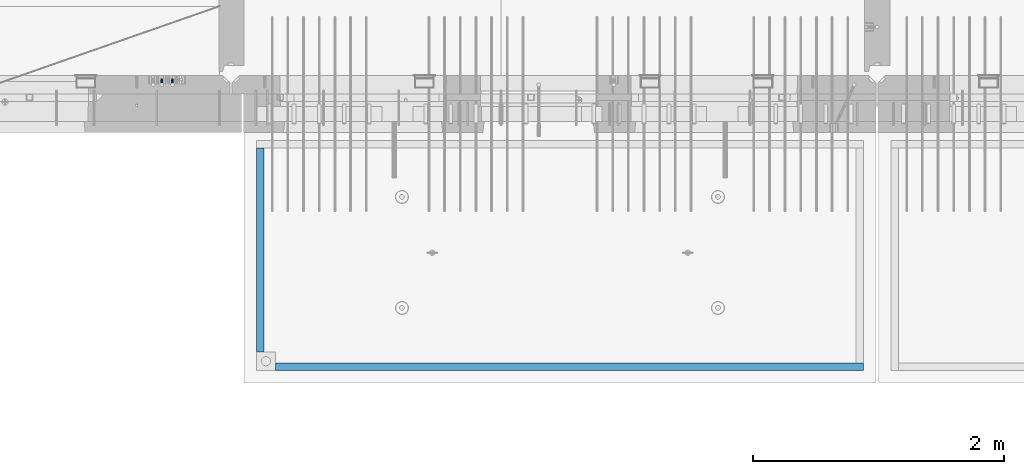
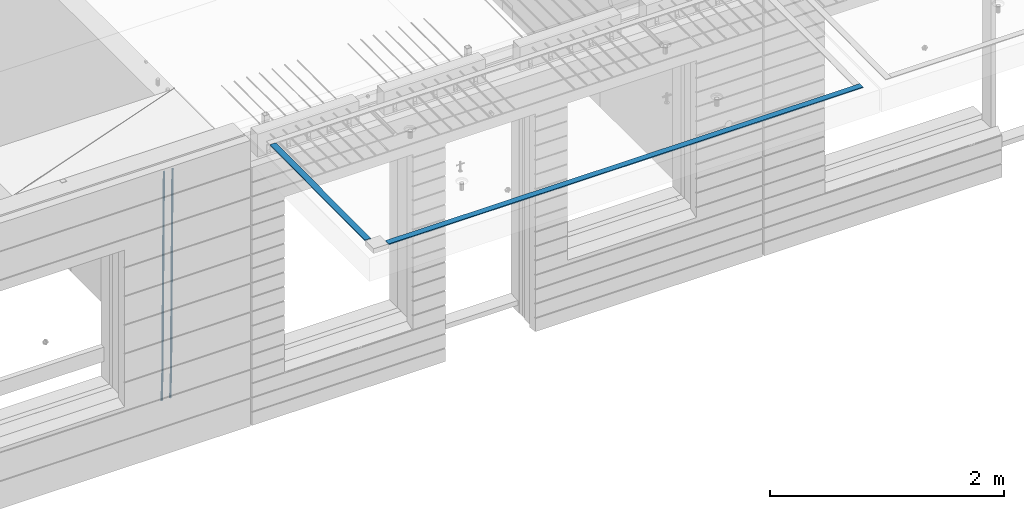
# One storey, part 95 of 349: 4 beams, 2 elements without a shape of their own.
"""IFC2X3 building model written with IfcOpenShell, lengths in millimetres."""

from ifc_helpers import new_model, si_unit, frame, origin_with_axes, place, context, subcontext, project, spatial, faceted_brep, material, type_object, element, aggregate, save


model = new_model("IFC2X3")

# Units and contexts
model_context = context("Model", 3, precision=1e-05, world=origin_with_axes())
body_context = subcontext(model_context, "Body", "Model", "MODEL_VIEW")
ifc_project = project(units=[si_unit("LENGTHUNIT", "METRE", prefix="MILLI"), si_unit("AREAUNIT", "SQUARE_METRE"), si_unit("VOLUMEUNIT", "CUBIC_METRE"), si_unit("MASSUNIT", "GRAM", prefix="KILO"), si_unit("TIMEUNIT", "SECOND"), si_unit("PLANEANGLEUNIT", "RADIAN"), si_unit("SOLIDANGLEUNIT", "STERADIAN"), si_unit("THERMODYNAMICTEMPERATUREUNIT", "DEGREE_CELSIUS"), si_unit("LUMINOUSINTENSITYUNIT", "LUMEN")], contexts=[model_context])

# Site, building, storey
site_placement = place(None, origin_with_axes())
site = spatial("IfcSite", under=ifc_project, at=site_placement, CompositionType="ELEMENT")
building_placement = place(site_placement, origin_with_axes())
building = spatial("IfcBuilding", under=site, at=building_placement, CompositionType="ELEMENT")
storey_placement = place(building_placement, origin_with_axes())
storey = spatial("IfcBuildingStorey", under=building, at=storey_placement, Name="4", CompositionType="ELEMENT", Elevation=0.0)

# Assembly, beams
assembly_1_placement = place(storey_placement, origin_with_axes())
assembly_1 = element("IfcElementAssembly", 1, at=assembly_1_placement, inside=storey, AssemblyPlace="NOTDEFINED", PredefinedType="REINFORCEMENT_UNIT")
ifc_material_1 = material()
beam_type_1 = type_object("IfcBeamType", Name="D20", PredefinedType="NOTDEFINED")
beam_1_placement = place(assembly_1_placement, frame((16189.9999999961, 7965.00000227913, 90990.0), z_axis=(0.00020576299992186, -0.999642804629538, -0.0267249099901004), x_axis=(-4.30000201928125e-08, -0.0267249099948059, 0.999642825806181)))
beam_1 = element("IfcBeam", 2, at=beam_1_placement, type_object=beam_type_1, material=ifc_material_1, Name="JM20", ObjectType="D20", context=body_context, shape_type="Brep", body=[
    faceted_brep([(0.0, -10.0, 0.0), (-4.19531716033816e-08, -7.07106781186667, -7.07106781187031), (60.4266690400545, -7.0710677960451, -7.07106780570757), (60.4266690441291, -9.99999998418934, 6.15546014159918e-09), (0.0, 0.0, -10.0), (60.426669036824, 1.58106558956206e-08, -9.99999999384454), (4.196772351861e-08, 7.07106781186303, -7.07106781186667), (60.4266690363438, 7.07106782768096, -7.07106780570757), (0.0, 10.0, 0.0), (60.4266690388904, 10.0000000158179, 6.15182216279209e-09), (4.196772351861e-08, 7.07106781185939, 7.07106781185939), (60.4266690429649, 7.07106782768096, 7.07106781802577), (0.0, 0.0, 10.0), (60.4266690461809, 1.58179318532348e-08, 10.0000000061555), (-4.19531716033816e-08, -7.07106781187031, 7.07106781185939), (60.4266690466611, -7.07106779605238, 7.07106781802213), (61.0378400410118, -7.07106779588503, -7.07106780564936), (60.991799419251, -9.99999998403655, 6.21366780251265e-09), (61.0569027789461, 1.5985278878361e-08, -9.99999999378269), (61.0378209396877, 7.07106782784831, -7.07106780564936), (60.9917724058905, 10.0000000159635, 6.21366780251265e-09), (60.9457317841297, 7.07106782781193, 7.0710678180767), (60.9266690461809, 1.59488990902901e-08, 10.0000000062028), (60.9457508854539, -7.07106779591413, 7.0710678180767), (61.6489592143771, -7.07106614513759, -7.06310863441468), (61.5568818710308, -9.9999984576425, 0.00735959856683621), (61.6870830769039, 1.71821739058942e-06, -9.99179257185824), (61.6489210170112, 7.07106947854481, -7.06310888312146), (61.556827851804, 10.0000015422847, 0.00735924683976918), (61.4647505084577, 7.07106922979438, 7.07782747982128), (61.4266266459163, 1.36643211590126e-06, 10.0065114172685), (61.464788705809, -7.07106639389531, 7.07782772852806), (176.543135720174, -7.07075579406956, -5.56673531796696), (176.451058376813, -9.99968810657447, 1.50373291501455), (176.581259582701, 0.000312069292704109, -8.49541925541052), (176.543097522794, 7.07137982961285, -5.56673556667374), (176.451004357587, 10.00031189336, 1.50373256329476), (176.35892701424, 7.07137958085514, 8.57420079627263), (176.320803151699, 0.000311717507429421, 11.5028847337162), (176.358965211621, -7.07075604281999, 8.57420104497578), (177.098753836006, -7.07075429323595, -5.55949898843028), (176.98362511232, -9.99968666800123, 1.510669025065), (177.146421932586, 0.000313595905026887, -8.48805862247536), (177.098706077581, 7.07138133041735, -5.55949936166144), (176.983557571715, 10.0003133318824, 1.51066849724157), (176.868428848029, 7.07138095712435, 8.58083651073321), (176.820760751449, 0.000313067976094317, 11.5093961447819), (176.868476606425, -7.07075466652896, 8.58083688396073), (177.654312950661, -7.07075204110879, -5.54863964998367), (177.516135294456, -9.99968450931192, 1.52107783331303), (177.711524267797, 0.000315886711177882, -8.47701274570863), (177.654255632195, 7.07138358250813, -5.54864021007961), (177.516054233929, 10.0003154905207, 1.5210770412159), (177.377876577739, 7.0713830223176, 8.59079452451624), (177.320665260588, 0.000315094497636892, 11.5191676202448), (177.377933896176, -7.07075260129932, 8.59079508461218), (299.436796249574, -7.07025836271714, -3.1681962331204), (299.298618593355, -9.99919083092027, 3.90152125031091), (299.494007566798, 0.000809565110102994, -6.09656932889993), (299.436738931283, 7.07187726089978, -3.16819679320906), (299.298537533061, 10.0008091689197, 3.90152045822106), (299.160359876842, 7.07187670072017, 10.9712379416487), (299.103148559603, 0.000808772889286047, 13.8996110374392), (299.160417195119, -7.07025892290039, 10.9712385017483), (299.98743051647, -7.07025613056248, -3.15743315966392), (299.971788958996, -9.99918809853989, 3.91467979818117), (299.993912075952, 0.000811591617093654, -6.08679785393178), (299.987423933868, 7.07187949325817, -3.1574327280432), (299.971753863239, 10.0008119014747, 3.91467990454839), (299.95611230444, 7.07187992653053, 10.9867922621015), (299.949630744944, 0.000812204350950196, 13.9161569563694), (299.956118887014, -7.07025569729012, 10.9867918304735), (300.538107039494, -7.07025785017686, -3.16575821840888), (300.644985195438, -9.99919020432935, 3.90450175465594), (300.493854948218, 0.000810030429420294, -6.09435592770024), (300.538151196495, 7.071877773491, -3.16575855385963), (300.645047642858, 10.0008097955724, 3.90450128024895), (300.751925798773, 7.07187744142357, 10.9747612533101), (300.796177890064, 0.000809560813650023, 13.9033589625978), (300.751881641787, -7.07025818224065, 10.9747615887682), (2293.36490490142, -7.07648090940347, -33.2930642912361), (2293.47178305736, -10.0054132635523, -26.2228043181785), (2293.32065281013, -0.00541302880083094, -36.2216620005347), (2293.36494905842, 7.06565471425711, -33.2930646266868), (2293.47184550477, 9.99458673634581, -26.2228047925819), (2293.57872366071, 7.06565438219332, -19.1525448195243), (2293.62297575199, -0.00541349841296324, -16.2239471102366), (2293.57867950371, -7.0764812414709, -19.1525444840736), (2294.0658245362, -7.07648309818615, -33.3036607065333), (2294.05312277409, -10.0054150789219, -26.2315929392535), (2294.10928714235, -0.00541549149056664, -36.2335844756526), (2294.15805078732, 7.06565223761572, -33.3050546393533), (2294.18355038921, 9.99458451388637, -26.2335642579346), (2294.17084862708, 7.06565253314329, -19.1614964906439), (2294.12738602093, -0.00541507354500936, -16.2315727215355), (2294.07862237596, -7.07648280265857, -19.1601025578348), (2294.76670261032, -7.08562269121467, -33.294332712383), (2294.63442802057, -10.0129954178956, -26.2238563411993), (2294.89787471293, -0.0156988342423574, -36.2230891548279), (2294.95110548967, 7.05531064255774, -33.2944998654275), (2294.89521307347, 9.98530428734011, -26.2240927312887), (2294.76293848372, 7.0579315606592, -19.1536163601049), (2294.63176638114, -0.0119922963167483, -16.2248599176673), (2294.57853560438, -7.08300177311321, -19.1534492070678), (2316.52657204497, -7.36937582653991, -33.0047303660212), (2316.39429745522, -10.2967485532172, -25.9342539948302), (2316.65774414754, -0.299451969567599, -35.9334868084661), (2316.7109749243, 6.7715575072325, -33.0048975190657), (2316.65508250811, 9.70155115201487, -25.9344903849269), (2316.52280791836, 6.7741784253376, -18.8640140137468), (2316.39163581574, -0.295745431634714, -15.9352575713092), (2316.33840503903, -7.36675490843481, -18.863846860706), (2317.16202064224, -7.37766220584308, -32.9962731735213), (2317.05438744847, -10.3053562613532, -25.9254688497131), (2317.23607125619, -0.306993473008333, -35.925789846493), (2317.23316144495, 6.76474808850253, -32.9979477328052), (2317.15499573652, 9.6950321815566, -25.9278370341635), (2317.04736254275, 6.7673381260538, -18.8570327103698), (2316.97331192881, -0.303330606784584, -15.9275160373909), (2316.97622174003, -7.37507216829545, -18.8553581510787), (2317.79752306276, -7.37578610372293, -32.9880110666527), (2317.71453320107, -10.3033876998124, -25.9168792378296), (2317.81444760226, -0.305295583297266, -35.918287695793), (2317.75539265381, 6.76628640723357, -32.9911928173897), (2317.65495180529, 9.69652304524061, -25.9213789128698), (2317.5719619436, 6.76892144914746, -18.8502470840467), (2317.55503740412, -0.301569071270933, -15.9199704549137), (2317.61409235255, -7.3731510618054, -18.847065333317), (2417.8183084176, -7.07752398473531, -31.6906369377139), (2417.73531855589, -10.0051255808248, -24.6195051088798), (2417.83523295709, -0.007033464313281, -34.6209135668432), (2417.77617800863, 7.06454852621755, -31.6938186884508), (2417.67573716014, 9.99478516423187, -24.6240047839383), (2417.59274729842, 7.06718356813872, -17.5528729551006), (2417.57582275895, -0.00330695228694822, -14.6225963259749), (2417.6348777074, -7.07488894281778, -17.5496912043673)], [[[0, 1, 2, 3]], [[1, 4, 5, 2]], [[4, 6, 7, 5]], [[6, 8, 9, 7]], [[8, 10, 11, 9]], [[10, 12, 13, 11]], [[12, 14, 15, 13]], [[14, 0, 3, 15]], [[14, 12, 10, 8, 6, 4, 1, 0]], [[3, 2, 16, 17]], [[2, 5, 18, 16]], [[5, 7, 19, 18]], [[7, 9, 20, 19]], [[9, 11, 21, 20]], [[11, 13, 22, 21]], [[13, 15, 23, 22]], [[15, 3, 17, 23]], [[17, 16, 24, 25]], [[16, 18, 26, 24]], [[18, 19, 27, 26]], [[19, 20, 28, 27]], [[20, 21, 29, 28]], [[21, 22, 30, 29]], [[22, 23, 31, 30]], [[23, 17, 25, 31]], [[25, 24, 32, 33]], [[24, 26, 34, 32]], [[26, 27, 35, 34]], [[27, 28, 36, 35]], [[28, 29, 37, 36]], [[29, 30, 38, 37]], [[30, 31, 39, 38]], [[31, 25, 33, 39]], [[33, 32, 40, 41]], [[32, 34, 42, 40]], [[34, 35, 43, 42]], [[35, 36, 44, 43]], [[36, 37, 45, 44]], [[37, 38, 46, 45]], [[38, 39, 47, 46]], [[39, 33, 41, 47]], [[41, 40, 48, 49]], [[40, 42, 50, 48]], [[42, 43, 51, 50]], [[43, 44, 52, 51]], [[44, 45, 53, 52]], [[45, 46, 54, 53]], [[46, 47, 55, 54]], [[47, 41, 49, 55]], [[49, 48, 56, 57]], [[48, 50, 58, 56]], [[50, 51, 59, 58]], [[51, 52, 60, 59]], [[52, 53, 61, 60]], [[53, 54, 62, 61]], [[54, 55, 63, 62]], [[55, 49, 57, 63]], [[57, 56, 64, 65]], [[56, 58, 66, 64]], [[58, 59, 67, 66]], [[59, 60, 68, 67]], [[60, 61, 69, 68]], [[61, 62, 70, 69]], [[62, 63, 71, 70]], [[63, 57, 65, 71]], [[65, 64, 72, 73]], [[64, 66, 74, 72]], [[66, 67, 75, 74]], [[67, 68, 76, 75]], [[68, 69, 77, 76]], [[69, 70, 78, 77]], [[70, 71, 79, 78]], [[71, 65, 73, 79]], [[73, 72, 80, 81]], [[72, 74, 82, 80]], [[74, 75, 83, 82]], [[75, 76, 84, 83]], [[76, 77, 85, 84]], [[77, 78, 86, 85]], [[78, 79, 87, 86]], [[79, 73, 81, 87]], [[81, 80, 88, 89]], [[80, 82, 90, 88]], [[82, 83, 91, 90]], [[83, 84, 92, 91]], [[84, 85, 93, 92]], [[85, 86, 94, 93]], [[86, 87, 95, 94]], [[87, 81, 89, 95]], [[89, 88, 96, 97]], [[88, 90, 98, 96]], [[90, 91, 99, 98]], [[91, 92, 100, 99]], [[92, 93, 101, 100]], [[93, 94, 102, 101]], [[94, 95, 103, 102]], [[95, 89, 97, 103]], [[97, 96, 104, 105]], [[96, 98, 106, 104]], [[98, 99, 107, 106]], [[99, 100, 108, 107]], [[100, 101, 109, 108]], [[101, 102, 110, 109]], [[102, 103, 111, 110]], [[103, 97, 105, 111]], [[105, 104, 112, 113]], [[104, 106, 114, 112]], [[106, 107, 115, 114]], [[107, 108, 116, 115]], [[108, 109, 117, 116]], [[109, 110, 118, 117]], [[110, 111, 119, 118]], [[111, 105, 113, 119]], [[113, 112, 120, 121]], [[112, 114, 122, 120]], [[114, 115, 123, 122]], [[115, 116, 124, 123]], [[116, 117, 125, 124]], [[117, 118, 126, 125]], [[118, 119, 127, 126]], [[119, 113, 121, 127]], [[121, 120, 128, 129]], [[120, 122, 130, 128]], [[122, 123, 131, 130]], [[123, 124, 132, 131]], [[124, 125, 133, 132]], [[125, 126, 134, 133]], [[126, 127, 135, 134]], [[127, 121, 129, 135]], [[130, 131, 132, 133, 134, 135, 129, 128]]]),
])
beam_2_placement = place(assembly_1_placement, frame((16104.9999999961, 7965.00000227913, 90990.0), z_axis=(0.00020576299992186, -0.999642804629538, -0.0267249099901004), x_axis=(-4.30000201928125e-08, -0.0267249099948059, 0.999642825806181)))
beam_2 = element("IfcBeam", 3, at=beam_2_placement, type_object=beam_type_1, material=ifc_material_1, Name="JM20", ObjectType="D20", context=body_context, shape_type="Brep", body=[
    faceted_brep([(0.0, -10.0, 0.0), (-4.19531716033816e-08, -7.07106781186667, -7.07106781187031), (60.4266690400545, -7.0710677960451, -7.07106780570757), (60.4266690441291, -9.99999998418934, 6.15546014159918e-09), (0.0, 0.0, -10.0), (60.426669036824, 1.58106558956206e-08, -9.99999999384454), (4.196772351861e-08, 7.07106781186303, -7.07106781186667), (60.4266690363438, 7.07106782768096, -7.07106780570757), (0.0, 10.0, 0.0), (60.4266690388904, 10.0000000158179, 6.15182216279209e-09), (4.196772351861e-08, 7.07106781185939, 7.07106781185939), (60.4266690429649, 7.07106782768096, 7.07106781802577), (0.0, 0.0, 10.0), (60.4266690461809, 1.58179318532348e-08, 10.0000000061555), (-4.19531716033816e-08, -7.07106781187031, 7.07106781185939), (60.4266690466611, -7.07106779605238, 7.07106781802213), (61.0378400410118, -7.07106779588503, -7.07106780564936), (60.991799419251, -9.99999998403655, 6.21366780251265e-09), (61.0569027789461, 1.5985278878361e-08, -9.99999999378269), (61.0378209396877, 7.07106782784831, -7.07106780564936), (60.9917724058905, 10.0000000159635, 6.21366780251265e-09), (60.9457317841297, 7.07106782781193, 7.0710678180767), (60.9266690461809, 1.59488990902901e-08, 10.0000000062028), (60.9457508854539, -7.07106779591413, 7.0710678180767), (61.6489592143771, -7.07106614513759, -7.06310863441468), (61.5568818710308, -9.9999984576425, 0.00735959856683621), (61.6870830769039, 1.71821739058942e-06, -9.99179257185824), (61.6489210170112, 7.07106947854481, -7.06310888312146), (61.556827851804, 10.0000015422847, 0.00735924683976918), (61.4647505084577, 7.07106922979438, 7.07782747982128), (61.4266266459163, 1.36643211590126e-06, 10.0065114172685), (61.464788705809, -7.07106639389531, 7.07782772852806), (176.543135720174, -7.07075579406956, -5.56673531796696), (176.451058376813, -9.99968810657447, 1.50373291501455), (176.581259582701, 0.000312069292704109, -8.49541925541052), (176.543097522794, 7.07137982961285, -5.56673556667374), (176.451004357587, 10.00031189336, 1.50373256329476), (176.35892701424, 7.07137958085514, 8.57420079627263), (176.320803151699, 0.000311717507429421, 11.5028847337162), (176.358965211621, -7.07075604281999, 8.57420104497578), (177.098753836006, -7.07075429323595, -5.55949898843028), (176.98362511232, -9.99968666800123, 1.510669025065), (177.146421932586, 0.000313595905026887, -8.48805862247536), (177.098706077581, 7.07138133041735, -5.55949936166144), (176.983557571715, 10.0003133318824, 1.51066849724157), (176.868428848029, 7.07138095712435, 8.58083651073321), (176.820760751449, 0.000313067976094317, 11.5093961447819), (176.868476606425, -7.07075466652896, 8.58083688396073), (177.654312950661, -7.07075204110879, -5.54863964998367), (177.516135294456, -9.99968450931192, 1.52107783331303), (177.711524267797, 0.000315886711177882, -8.47701274570863), (177.654255632195, 7.07138358250813, -5.54864021007961), (177.516054233929, 10.0003154905207, 1.5210770412159), (177.377876577739, 7.0713830223176, 8.59079452451624), (177.320665260588, 0.000315094497636892, 11.5191676202448), (177.377933896176, -7.07075260129932, 8.59079508461218), (299.436796249574, -7.07025836271714, -3.1681962331204), (299.298618593355, -9.99919083092027, 3.90152125031091), (299.494007566798, 0.000809565110102994, -6.09656932889993), (299.436738931283, 7.07187726089978, -3.16819679320906), (299.298537533061, 10.0008091689197, 3.90152045822106), (299.160359876842, 7.07187670072017, 10.9712379416487), (299.103148559603, 0.000808772889286047, 13.8996110374392), (299.160417195119, -7.07025892290039, 10.9712385017483), (299.98743051647, -7.07025613056248, -3.15743315966392), (299.971788958996, -9.99918809853989, 3.91467979818117), (299.993912075952, 0.000811591617093654, -6.08679785393178), (299.987423933868, 7.07187949325817, -3.1574327280432), (299.971753863239, 10.0008119014747, 3.91467990454839), (299.95611230444, 7.07187992653053, 10.9867922621015), (299.949630744944, 0.000812204350950196, 13.9161569563694), (299.956118887014, -7.07025569729012, 10.9867918304735), (300.538107039494, -7.07025785017686, -3.16575821840888), (300.644985195438, -9.99919020432935, 3.90450175465594), (300.493854948218, 0.000810030429420294, -6.09435592770024), (300.538151196495, 7.071877773491, -3.16575855385963), (300.645047642858, 10.0008097955724, 3.90450128024895), (300.751925798773, 7.07187744142357, 10.9747612533101), (300.796177890064, 0.000809560813650023, 13.9033589625978), (300.751881641787, -7.07025818224065, 10.9747615887682), (2293.36490490142, -7.07648090940347, -33.2930642912361), (2293.47178305736, -10.0054132635523, -26.2228043181785), (2293.32065281013, -0.00541302880083094, -36.2216620005347), (2293.36494905842, 7.06565471425711, -33.2930646266868), (2293.47184550477, 9.99458673634581, -26.2228047925819), (2293.57872366071, 7.06565438219332, -19.1525448195243), (2293.62297575199, -0.00541349841296324, -16.2239471102366), (2293.57867950371, -7.0764812414709, -19.1525444840736), (2294.0658245362, -7.07648309818615, -33.3036607065333), (2294.05312277409, -10.0054150789219, -26.2315929392535), (2294.10928714235, -0.00541549149056664, -36.2335844756526), (2294.15805078732, 7.06565223761572, -33.3050546393533), (2294.18355038921, 9.99458451388637, -26.2335642579346), (2294.17084862708, 7.06565253314329, -19.1614964906439), (2294.12738602093, -0.00541507354500936, -16.2315727215355), (2294.07862237596, -7.07648280265857, -19.1601025578348), (2294.76670261032, -7.08562269121467, -33.294332712383), (2294.63442802057, -10.0129954178956, -26.2238563411993), (2294.89787471293, -0.0156988342423574, -36.2230891548279), (2294.95110548967, 7.05531064255774, -33.2944998654275), (2294.89521307347, 9.98530428734011, -26.2240927312887), (2294.76293848372, 7.0579315606592, -19.1536163601049), (2294.63176638114, -0.0119922963167483, -16.2248599176673), (2294.57853560438, -7.08300177311321, -19.1534492070678), (2316.52657204497, -7.36937582653991, -33.0047303660212), (2316.39429745522, -10.2967485532172, -25.9342539948302), (2316.65774414754, -0.299451969567599, -35.9334868084661), (2316.7109749243, 6.7715575072325, -33.0048975190657), (2316.65508250811, 9.70155115201487, -25.9344903849269), (2316.52280791836, 6.7741784253376, -18.8640140137468), (2316.39163581574, -0.295745431634714, -15.9352575713092), (2316.33840503903, -7.36675490843481, -18.863846860706), (2317.16202064224, -7.37766220584308, -32.9962731735213), (2317.05438744847, -10.3053562613532, -25.9254688497131), (2317.23607125619, -0.306993473008333, -35.925789846493), (2317.23316144495, 6.76474808850253, -32.9979477328052), (2317.15499573652, 9.6950321815566, -25.9278370341635), (2317.04736254275, 6.7673381260538, -18.8570327103698), (2316.97331192881, -0.303330606784584, -15.9275160373909), (2316.97622174003, -7.37507216829545, -18.8553581510787), (2317.79752306276, -7.37578610372293, -32.9880110666527), (2317.71453320107, -10.3033876998124, -25.9168792378296), (2317.81444760226, -0.305295583297266, -35.918287695793), (2317.75539265381, 6.76628640723357, -32.9911928173897), (2317.65495180529, 9.69652304524061, -25.9213789128698), (2317.5719619436, 6.76892144914746, -18.8502470840467), (2317.55503740412, -0.301569071270933, -15.9199704549137), (2317.61409235255, -7.3731510618054, -18.847065333317), (2417.8183084176, -7.07752398473531, -31.6906369377139), (2417.73531855589, -10.0051255808248, -24.6195051088798), (2417.83523295709, -0.007033464313281, -34.6209135668432), (2417.77617800863, 7.06454852621755, -31.6938186884508), (2417.67573716014, 9.99478516423187, -24.6240047839383), (2417.59274729842, 7.06718356813872, -17.5528729551006), (2417.57582275895, -0.00330695228694822, -14.6225963259749), (2417.6348777074, -7.07488894281778, -17.5496912043673)], [[[0, 1, 2, 3]], [[1, 4, 5, 2]], [[4, 6, 7, 5]], [[6, 8, 9, 7]], [[8, 10, 11, 9]], [[10, 12, 13, 11]], [[12, 14, 15, 13]], [[14, 0, 3, 15]], [[14, 12, 10, 8, 6, 4, 1, 0]], [[3, 2, 16, 17]], [[2, 5, 18, 16]], [[5, 7, 19, 18]], [[7, 9, 20, 19]], [[9, 11, 21, 20]], [[11, 13, 22, 21]], [[13, 15, 23, 22]], [[15, 3, 17, 23]], [[17, 16, 24, 25]], [[16, 18, 26, 24]], [[18, 19, 27, 26]], [[19, 20, 28, 27]], [[20, 21, 29, 28]], [[21, 22, 30, 29]], [[22, 23, 31, 30]], [[23, 17, 25, 31]], [[25, 24, 32, 33]], [[24, 26, 34, 32]], [[26, 27, 35, 34]], [[27, 28, 36, 35]], [[28, 29, 37, 36]], [[29, 30, 38, 37]], [[30, 31, 39, 38]], [[31, 25, 33, 39]], [[33, 32, 40, 41]], [[32, 34, 42, 40]], [[34, 35, 43, 42]], [[35, 36, 44, 43]], [[36, 37, 45, 44]], [[37, 38, 46, 45]], [[38, 39, 47, 46]], [[39, 33, 41, 47]], [[41, 40, 48, 49]], [[40, 42, 50, 48]], [[42, 43, 51, 50]], [[43, 44, 52, 51]], [[44, 45, 53, 52]], [[45, 46, 54, 53]], [[46, 47, 55, 54]], [[47, 41, 49, 55]], [[49, 48, 56, 57]], [[48, 50, 58, 56]], [[50, 51, 59, 58]], [[51, 52, 60, 59]], [[52, 53, 61, 60]], [[53, 54, 62, 61]], [[54, 55, 63, 62]], [[55, 49, 57, 63]], [[57, 56, 64, 65]], [[56, 58, 66, 64]], [[58, 59, 67, 66]], [[59, 60, 68, 67]], [[60, 61, 69, 68]], [[61, 62, 70, 69]], [[62, 63, 71, 70]], [[63, 57, 65, 71]], [[65, 64, 72, 73]], [[64, 66, 74, 72]], [[66, 67, 75, 74]], [[67, 68, 76, 75]], [[68, 69, 77, 76]], [[69, 70, 78, 77]], [[70, 71, 79, 78]], [[71, 65, 73, 79]], [[73, 72, 80, 81]], [[72, 74, 82, 80]], [[74, 75, 83, 82]], [[75, 76, 84, 83]], [[76, 77, 85, 84]], [[77, 78, 86, 85]], [[78, 79, 87, 86]], [[79, 73, 81, 87]], [[81, 80, 88, 89]], [[80, 82, 90, 88]], [[82, 83, 91, 90]], [[83, 84, 92, 91]], [[84, 85, 93, 92]], [[85, 86, 94, 93]], [[86, 87, 95, 94]], [[87, 81, 89, 95]], [[89, 88, 96, 97]], [[88, 90, 98, 96]], [[90, 91, 99, 98]], [[91, 92, 100, 99]], [[92, 93, 101, 100]], [[93, 94, 102, 101]], [[94, 95, 103, 102]], [[95, 89, 97, 103]], [[97, 96, 104, 105]], [[96, 98, 106, 104]], [[98, 99, 107, 106]], [[99, 100, 108, 107]], [[100, 101, 109, 108]], [[101, 102, 110, 109]], [[102, 103, 111, 110]], [[103, 97, 105, 111]], [[105, 104, 112, 113]], [[104, 106, 114, 112]], [[106, 107, 115, 114]], [[107, 108, 116, 115]], [[108, 109, 117, 116]], [[109, 110, 118, 117]], [[110, 111, 119, 118]], [[111, 105, 113, 119]], [[113, 112, 120, 121]], [[112, 114, 122, 120]], [[114, 115, 123, 122]], [[115, 116, 124, 123]], [[116, 117, 125, 124]], [[117, 118, 126, 125]], [[118, 119, 127, 126]], [[119, 113, 121, 127]], [[121, 120, 128, 129]], [[120, 122, 130, 128]], [[122, 123, 131, 130]], [[123, 124, 132, 131]], [[124, 125, 133, 132]], [[125, 126, 134, 133]], [[126, 127, 135, 134]], [[127, 121, 129, 135]], [[130, 131, 132, 133, 134, 135, 129, 128]]]),
])
aggregate(assembly_1, [beam_1, beam_2])

assembly_2_placement = place(storey_placement, origin_with_axes())
assembly_2 = element("IfcElementAssembly", 4, at=assembly_2_placement, inside=storey, AssemblyPlace="NOTDEFINED", PredefinedType="REINFORCEMENT_UNIT")
ifc_material_2 = material(Name="CONCRETE/Concrete_Undefined")
beam_type_2 = type_object("IfcBeamType", PredefinedType="NOTDEFINED")
beam_3_placement = place(assembly_2_placement, frame((17009.999743725, 5674.95858499901, 93709.8102146119), z_axis=(0.000380798000187366, 3.00000010760189e-09, 0.999999927496439), x_axis=(0.99999992747398, 6.70200000315108e-06, -0.000380798000181631)))
beam_3 = element("IfcBeam", 5, at=beam_3_placement, type_object=beam_type_2, material=ifc_material_2, context=body_context, shape_type="Brep", body=[
    faceted_brep([(2.5465851649642e-11, 29.9999999999982, -4.99999999998545), (-2.91038304567337e-11, 29.9999999999982, 5.0), (4690.00295566467, 30.0, 5.00000000001455), (4690.00295566467, 30.0000000000009, -4.99999999998545), (-2.5465851649642e-11, -30.0000000000018, 5.0), (4690.00295566467, -30.0, 5.00000000001455), (2.72848410531878e-11, -30.0000000000018, -4.99999999998545), (4690.00295566467, -30.0, -5.0)], [[[0, 1, 2, 3]], [[1, 4, 5, 2]], [[4, 6, 7, 5]], [[6, 0, 3, 7]], [[5, 7, 3, 2]], [[6, 4, 1, 0]]]),
])
beam_4_placement = place(assembly_2_placement, frame((16889.9913896902, 7420.06323332097, 93723.6636421195), z_axis=(3.06000001756964e-07, -0.00861454800079991, 0.9999628940929), x_axis=(3.55420000171828e-05, -0.999962893461279, -0.00861454800397781)))
beam_4 = element("IfcBeam", 6, at=beam_4_placement, type_object=beam_type_2, material=ifc_material_2, context=body_context, shape_type="Brep", body=[
    faceted_brep([(2.5465851649642e-11, 29.9999999999982, -4.99999999998545), (-2.91038304567337e-11, 29.9999999999982, 5.0), (1625.15608040099, 30.0000000000073, 5.0), (1625.15608040101, 30.0000000000036, -4.99999999998545), (-2.5465851649642e-11, -30.0000000000018, 5.0), (1625.15608040099, -29.9999999999964, 5.0), (2.72848410531878e-11, -30.0000000000018, -4.99999999998545), (1625.15608040101, -29.9999999999964, -4.99999999998545)], [[[0, 1, 2, 3]], [[1, 4, 5, 2]], [[4, 6, 7, 5]], [[6, 0, 3, 7]], [[5, 7, 3, 2]], [[6, 4, 1, 0]]]),
])
aggregate(assembly_2, [beam_3, beam_4])

save(model, "model.ifc")
